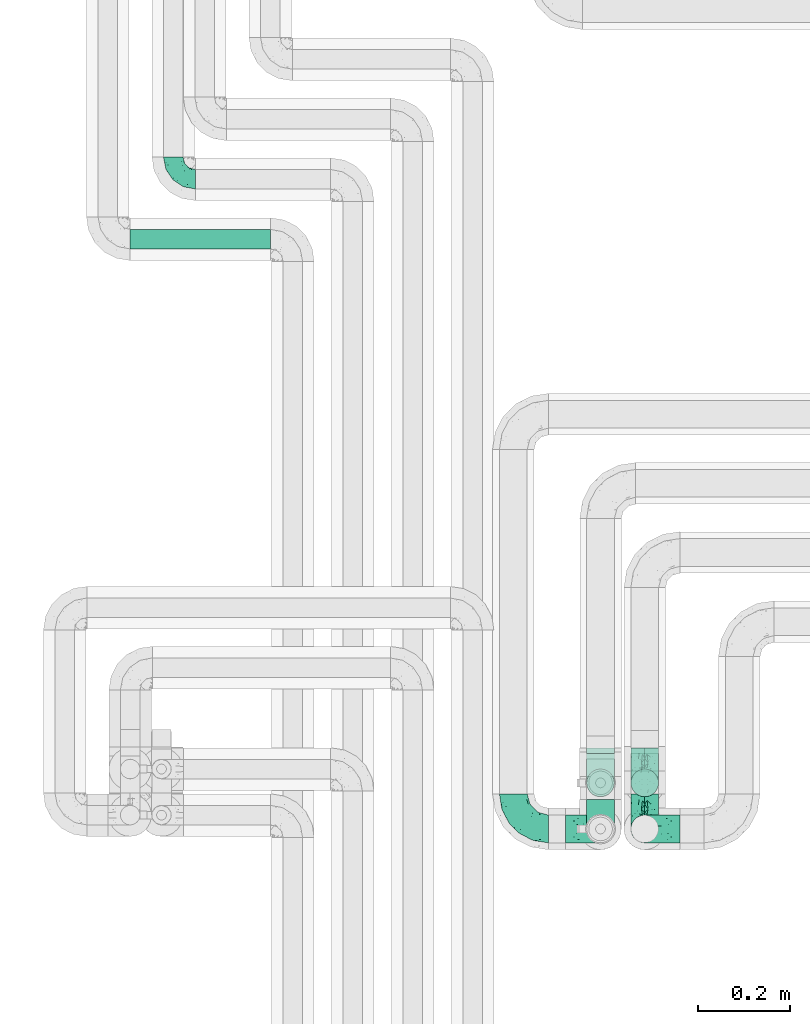
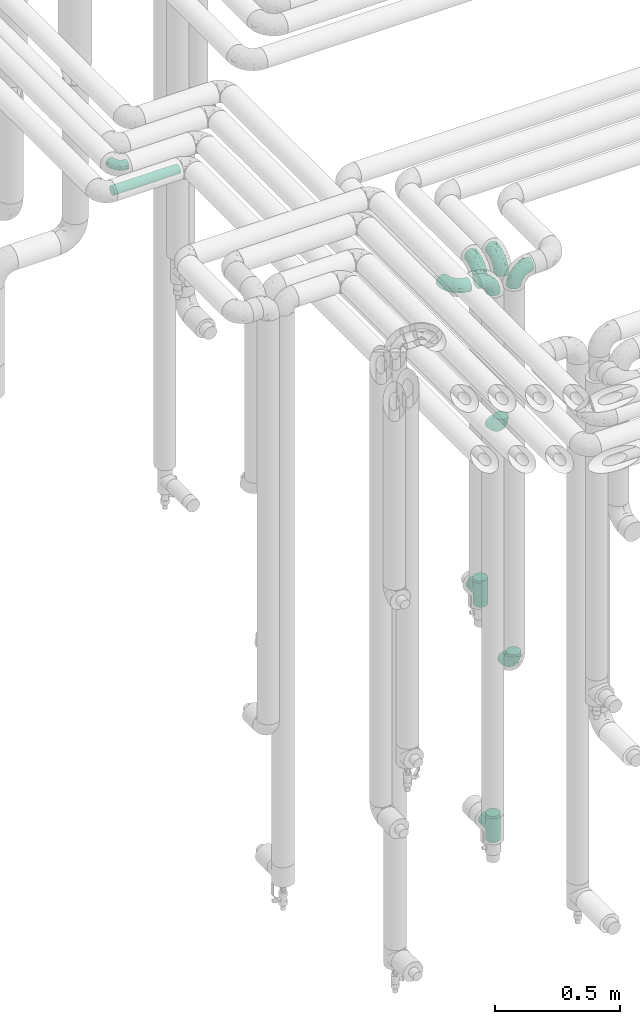
# One storey, part 632 of 824: 10 flow fittings, 1 flow segment.
"""IFC2X3 building model written with IfcOpenShell, lengths in millimetres."""

from ifc_helpers import new_model, entity, si_unit, converted_unit, derived_unit, direction, frame, origin, origin_2d_with_axis, place, context, subcontext, project, spatial, circle, extrude, faceted_brep, source, transform, mapped, material, type_object, type_shapes, element, save


model = new_model("IFC2X3")

# Units and contexts
model_context = context("Model", 3, precision=0.01, world=origin(), true_north=direction((6.12303176911189e-17, 1.0)))
body_context = subcontext(model_context, "Body", "Model", "MODEL_VIEW")
ifc_project = project(units=[si_unit("LENGTHUNIT", "METRE", prefix="MILLI"), si_unit("AREAUNIT", "SQUARE_METRE"), si_unit("VOLUMEUNIT", "CUBIC_METRE"), converted_unit("PLANEANGLEUNIT", "DEGREE", entity("IfcRatioMeasure", 0.0174532925199433), si_unit("PLANEANGLEUNIT", "RADIAN"), dimensions=[0, 0, 0, 0, 0, 0, 0]), si_unit("MASSUNIT", "GRAM", prefix="KILO"), derived_unit("MASSDENSITYUNIT", [(si_unit("MASSUNIT", "GRAM", prefix="KILO"), 1), (si_unit("LENGTHUNIT", "METRE"), -3)]), derived_unit("MOMENTOFINERTIAUNIT", [(si_unit("LENGTHUNIT", "METRE"), 4)]), si_unit("TIMEUNIT", "SECOND"), si_unit("FREQUENCYUNIT", "HERTZ"), si_unit("THERMODYNAMICTEMPERATUREUNIT", "DEGREE_CELSIUS"), derived_unit("THERMALTRANSMITTANCEUNIT", [(si_unit("MASSUNIT", "GRAM", prefix="KILO"), 1), (si_unit("THERMODYNAMICTEMPERATUREUNIT", "KELVIN"), -1), (si_unit("TIMEUNIT", "SECOND"), -3)]), derived_unit("VOLUMETRICFLOWRATEUNIT", [(si_unit("LENGTHUNIT", "METRE"), 3), (si_unit("TIMEUNIT", "SECOND"), -1)]), derived_unit("MASSFLOWRATEUNIT", [(si_unit("MASSUNIT", "GRAM", prefix="KILO"), 1), (si_unit("TIMEUNIT", "SECOND"), -1)]), derived_unit("ROTATIONALFREQUENCYUNIT", [(si_unit("TIMEUNIT", "SECOND"), -1)]), si_unit("ELECTRICCURRENTUNIT", "AMPERE"), si_unit("ELECTRICVOLTAGEUNIT", "VOLT"), si_unit("POWERUNIT", "WATT"), si_unit("FORCEUNIT", "NEWTON", prefix="KILO"), si_unit("ILLUMINANCEUNIT", "LUX"), si_unit("LUMINOUSFLUXUNIT", "LUMEN"), si_unit("LUMINOUSINTENSITYUNIT", "CANDELA"), derived_unit("USERDEFINED", [(si_unit("MASSUNIT", "GRAM", prefix="KILO"), -1), (si_unit("LENGTHUNIT", "METRE"), -2), (si_unit("TIMEUNIT", "SECOND"), 3), (si_unit("LUMINOUSFLUXUNIT", "LUMEN"), 1)]), derived_unit("LINEARVELOCITYUNIT", [(si_unit("LENGTHUNIT", "METRE"), 1), (si_unit("TIMEUNIT", "SECOND"), -1)]), si_unit("PRESSUREUNIT", "PASCAL"), derived_unit("USERDEFINED", [(si_unit("LENGTHUNIT", "METRE"), -2), (si_unit("MASSUNIT", "GRAM", prefix="KILO"), 1), (si_unit("TIMEUNIT", "SECOND"), -2)]), derived_unit("LINEARFORCEUNIT", [(si_unit("MASSUNIT", "GRAM", prefix="KILO"), 1), (si_unit("LENGTHUNIT", "METRE"), 1), (si_unit("TIMEUNIT", "SECOND"), -2), (si_unit("LENGTHUNIT", "METRE"), -1)]), derived_unit("PLANARFORCEUNIT", [(si_unit("MASSUNIT", "GRAM", prefix="KILO"), 1), (si_unit("LENGTHUNIT", "METRE"), 1), (si_unit("TIMEUNIT", "SECOND"), -2), (si_unit("LENGTHUNIT", "METRE"), -2)])], contexts=[model_context])

# Site, building, storey
site_placement = place(None, origin())
site = spatial("IfcSite", under=ifc_project, at=site_placement, CompositionType="ELEMENT")
building_placement = place(site_placement, origin())
building = spatial("IfcBuilding", under=site, at=building_placement, CompositionType="ELEMENT")
storey_placement = place(building_placement, frame((0.0, 0.0, 28200.0)))
storey = spatial("IfcBuildingStorey", under=building, at=storey_placement, CompositionType="ELEMENT", Elevation=28200.0)

# Flow segment
pipe_segment_type = type_object("IfcPipeSegmentType", PredefinedType="NOTDEFINED")
flow_segment_placement = place(storey_placement, frame((30563.05, 16968.46, 2977.25)))
element("IfcFlowSegment", 1, at=flow_segment_placement, inside=storey, type_object=pipe_segment_type, context=body_context, shape_type="SweptSolid", body=[
    extrude(circle(Radius=21.15, at=origin_2d_with_axis()), frame((0.0, 22.75, 22.75), z_axis=(1.0, 0.0, 0.0), x_axis=(0.0, -1.0, 0.0)), (0.0, 0.0, 1.0), 305.473199999971),
])

# Flow fittings
ifc_material = material()
pipe_fitting_type_1 = type_object("IfcPipeFittingType", PredefinedType="NOTDEFINED", material=ifc_material)
shared_shape_1 = source(origin(), body_context, "Body", "Brep", [
    faceted_brep([(-48.0, 10.6, -18.36), (-48.0, 5.49, -20.48), (-48.0, 0.0, -21.2), (-48.0, -5.49, -20.48), (-48.0, -10.6, -18.36), (-48.0, -14.99, -14.99), (-48.0, -18.36, -10.6), (-48.0, -20.48, -5.49), (-48.0, -21.2, 0.0), (-48.0, -20.48, 5.49), (-48.0, -18.36, 10.6), (-48.0, -14.99, 14.99), (-48.0, -10.6, 18.36), (-48.0, -5.49, 20.48), (-48.0, 0.0, 21.2), (-48.0, 5.49, 20.48), (-48.0, 10.6, 18.36), (-48.0, 14.99, 14.99), (-48.0, 18.36, 10.6), (-48.0, 20.48, 5.49), (-48.0, 21.2, 0.0), (-48.0, 20.48, -5.49), (-48.0, 18.36, -10.6), (-48.0, 14.99, -14.99), (0.0, 48.0, -21.2), (-5.49, 48.0, -20.48), (-10.6, 48.0, -18.36), (-14.99, 48.0, -14.99), (-18.36, 48.0, -10.6), (-20.48, 48.0, -5.49), (-21.2, 48.0, 0.0), (-20.48, 48.0, 5.49), (-18.36, 48.0, 10.6), (-14.99, 48.0, 14.99), (-10.6, 48.0, 18.36), (-5.49, 48.0, 20.48), (0.0, 48.0, 21.2), (5.49, 48.0, 20.48), (10.6, 48.0, 18.36), (14.99, 48.0, 14.99), (18.36, 48.0, 10.6), (20.48, 48.0, 5.49), (21.2, 48.0, 0.0), (20.48, 48.0, -5.49), (18.36, 48.0, -10.6), (14.99, 48.0, -14.99), (10.6, 48.0, -18.36), (5.49, 48.0, -20.48), (-35.25, -16.22, 12.01), (-34.76, -18.57, 0.0), (-20.87, -12.37, 10.9), (-31.49, -11.78, 15.9), (-37.0, -2.58, 20.86), (-33.89, 3.62, 21.15), (-31.81, -18.14, 6.76), (-5.78, 5.78, 17.67), (-19.42, -4.1, 17.86), (-9.6, -3.39, 13.73), (-35.44, -7.73, 19.13), (11.78, 31.49, 15.9), (-5.93, -5.46, 6.95), (-18.45, -13.78, 5.46), (-10.29, -8.43, 0.0), (-24.6, 0.55, 20.62), (-37.28, 17.94, 13.81), (-33.38, 22.85, 9.59), (-41.46, 20.06, 8.75), (-29.51, 20.45, 15.16), (-15.04, 10.79, 21.13), (-7.08, 16.98, 20.93), (-8.39, 23.51, 21.15), (-40.86, 13.03, 17.26), (-8.05, 41.26, 19.83), (-3.21, 35.97, 21.14), (8.53, 19.66, 14.74), (4.1, 19.42, 17.86), (-37.72, 22.66, 4.78), (-37.07, 8.58, 19.98), (-13.0, 5.43, 19.97), (-3.78, 13.93, 19.7), (3.02, 8.69, 13.43), (-2.27, -0.05, 10.65), (6.22, 6.99, 7.09), (-22.25, 34.6, 9.45), (18.14, 31.81, 6.76), (16.22, 35.25, 12.01), (12.37, 20.87, 10.9), (7.73, 35.44, 19.13), (-21.52, -15.93, 0.0), (2.58, 37.0, 20.86), (18.57, 34.76, 0.0), (13.78, 18.45, 5.46), (15.93, 21.52, 0.0), (-20.03, -8.54, 14.9), (-28.6, 28.6, 5.16), (-24.79, 34.6, 0.0), (-34.6, 24.79, 0.0), (-22.81, 37.41, 4.68), (-23.36, 26.33, 14.79), (-13.68, 37.05, 17.49), (-17.72, 38.12, 13.73), (-26.25, 27.3, 11.24), (-9.71, 32.34, 20.14), (-17.26, 25.6, 18.71), (-26.33, 9.99, 20.77), (-24.06, 6.05, 21.2), (-25.02, 15.46, 19.56), (-24.3, 20.72, 17.57), (-31.95, 15.23, 17.8), (-13.53, 24.7, 20.21), (-17.6, 17.6, 20.6), (-0.55, 24.6, 20.62), (-11.41, -7.48, 10.43), (0.93, -0.93, 0.0), (8.43, 10.29, 0.0), (-11.41, -7.48, -10.43), (-20.1, -8.84, -14.66), (-9.6, -3.39, -13.73), (7.73, 35.44, -19.13), (4.1, 19.42, -17.86), (-0.55, 24.6, -20.62), (-38.12, 17.72, -13.73), (-37.05, 13.68, -17.49), (-32.34, 9.71, -20.14), (-41.26, 8.05, -19.83), (-37.41, 22.81, -4.68), (-23.51, 8.39, -21.15), (-35.97, 3.21, -21.14), (-28.6, 28.6, -5.16), (-31.81, -18.14, -6.76), (-18.45, -13.78, -5.46), (-25.6, 17.26, -18.71), (-19.42, -4.1, -17.86), (-17.94, 37.28, -13.81), (-22.85, 33.38, -9.59), (-20.06, 41.46, -8.75), (-31.49, -11.78, -15.9), (-35.25, -16.22, -12.01), (8.53, 19.66, -14.74), (11.78, 31.49, -15.9), (-9.99, 26.33, -20.77), (-6.05, 24.06, -21.2), (-10.79, 15.04, -21.13), (-37.0, -2.58, -20.86), (-16.98, 7.08, -20.93), (-5.43, 13.0, -19.97), (-13.93, 3.78, -19.7), (-20.87, -12.37, -10.9), (-26.33, 23.36, -14.79), (-22.66, 37.72, -4.78), (13.78, 18.45, -5.46), (18.14, 31.81, -6.76), (-15.46, 25.02, -19.56), (-20.72, 24.3, -17.57), (16.22, 35.25, -12.01), (-13.03, 40.86, -17.26), (-8.58, 37.07, -19.98), (2.58, 37.0, -20.86), (-3.62, 33.89, -21.15), (-34.6, 22.25, -9.45), (6.22, 6.99, -7.09), (-20.45, 29.51, -15.16), (-35.44, -7.73, -19.13), (12.37, 20.87, -10.9), (-27.3, 26.25, -11.24), (-15.23, 31.95, -17.8), (-24.7, 13.53, -20.21), (-24.6, 0.55, -20.62), (-5.78, 5.78, -17.67), (-17.6, 17.6, -20.6), (3.02, 8.69, -13.43), (-5.93, -5.46, -6.95), (-2.27, -0.05, -10.65)], [[[0, 1, 2, 3, 4, 5, 6, 7, 8, 9, 10, 11, 12, 13, 14, 15, 16, 17, 18, 19, 20, 21, 22, 23]], [[24, 25, 26, 27, 28, 29, 30, 31, 32, 33, 34, 35, 36, 37, 38, 39, 40, 41, 42, 43, 44, 45, 46, 47]], [[10, 48, 11]], [[9, 8, 49]], [[48, 50, 51]], [[14, 52, 53]], [[10, 54, 48]], [[9, 54, 10]], [[55, 56, 57]], [[51, 12, 11]], [[51, 58, 12]], [[59, 39, 38]], [[60, 61, 62]], [[58, 56, 63]], [[64, 65, 66]], [[67, 65, 64]], [[68, 69, 70]], [[16, 71, 17]], [[13, 52, 14]], [[35, 72, 73]], [[14, 53, 15]], [[17, 64, 18]], [[74, 59, 75]], [[20, 19, 76]], [[66, 19, 18]], [[77, 15, 53]], [[15, 77, 16]], [[69, 78, 79]], [[80, 81, 82]], [[32, 31, 83]], [[84, 85, 86]], [[59, 87, 75]], [[61, 54, 88]], [[36, 89, 37]], [[84, 41, 40]], [[36, 35, 73]], [[90, 41, 84]], [[40, 39, 85]], [[12, 58, 13]], [[85, 84, 40]], [[91, 84, 86]], [[84, 92, 90]], [[87, 38, 37]], [[93, 56, 51]], [[65, 94, 76]], [[94, 95, 96]], [[84, 91, 92]], [[95, 97, 30]], [[98, 99, 100]], [[76, 94, 96]], [[101, 98, 83]], [[100, 99, 33]], [[102, 70, 73]], [[103, 102, 99]], [[94, 97, 95]], [[72, 99, 102]], [[72, 35, 34]], [[34, 33, 99]], [[9, 49, 54]], [[87, 59, 38]], [[104, 105, 68]], [[106, 103, 107]], [[106, 77, 104]], [[71, 64, 17]], [[108, 107, 67]], [[33, 32, 100]], [[109, 103, 110]], [[102, 109, 70]], [[89, 73, 111]], [[50, 48, 54]], [[51, 11, 48]], [[56, 58, 51]], [[88, 54, 49]], [[52, 58, 63]], [[50, 112, 93]], [[56, 55, 78]], [[39, 59, 85]], [[86, 85, 59]], [[89, 87, 37]], [[42, 41, 90]], [[111, 79, 75]], [[111, 75, 87]], [[75, 55, 80]], [[104, 77, 53]], [[71, 77, 108]], [[32, 83, 100]], [[98, 100, 83]], [[99, 98, 103]], [[106, 107, 108]], [[68, 70, 110]], [[111, 73, 70]], [[68, 110, 104]], [[68, 63, 78]], [[57, 93, 112]], [[80, 55, 57]], [[61, 50, 54]], [[80, 82, 86]], [[81, 57, 112]], [[74, 86, 59]], [[60, 113, 82]], [[82, 114, 91]], [[101, 94, 65]], [[97, 94, 83]], [[73, 89, 36]], [[87, 89, 111]], [[58, 52, 13]], [[53, 52, 63]], [[104, 53, 105]], [[106, 104, 110]], [[20, 76, 96]], [[76, 19, 66]], [[103, 106, 110]], [[77, 106, 108]], [[103, 98, 107]], [[67, 107, 98]], [[67, 98, 101]], [[108, 67, 64]], [[53, 63, 105]], [[63, 68, 105]], [[83, 31, 97]], [[30, 97, 31]], [[62, 113, 60]], [[112, 61, 60]], [[61, 88, 62]], [[86, 82, 91]], [[56, 78, 63]], [[114, 82, 113]], [[114, 92, 91]], [[79, 78, 55]], [[75, 79, 55]], [[69, 79, 111]], [[70, 69, 111]], [[78, 69, 68]], [[77, 71, 16]], [[64, 71, 108]], [[64, 66, 18]], [[76, 66, 65]], [[99, 72, 34]], [[73, 72, 102]], [[94, 101, 83]], [[67, 101, 65]], [[75, 80, 74]], [[80, 86, 74]], [[70, 109, 110]], [[102, 103, 109]], [[50, 93, 51]], [[57, 56, 93]], [[61, 112, 50]], [[81, 112, 60]], [[82, 81, 60]], [[80, 57, 81]], [[115, 116, 117]], [[118, 119, 120]], [[121, 122, 23]], [[123, 124, 122]], [[96, 125, 20]], [[123, 126, 127]], [[128, 96, 95]], [[129, 130, 88]], [[123, 122, 131]], [[116, 132, 117]], [[133, 134, 135]], [[0, 124, 1]], [[5, 136, 137]], [[138, 119, 139]], [[129, 88, 49]], [[140, 141, 142]], [[6, 5, 137]], [[46, 118, 47]], [[143, 3, 2]], [[144, 145, 146]], [[6, 129, 7]], [[129, 137, 147]], [[127, 2, 1]], [[148, 122, 121]], [[128, 125, 96]], [[134, 128, 149]], [[95, 149, 128]], [[150, 151, 92]], [[30, 29, 149]], [[152, 131, 153]], [[27, 133, 28]], [[154, 45, 44]], [[136, 5, 4]], [[27, 26, 155]], [[156, 26, 25]], [[24, 157, 158]], [[24, 47, 157]], [[22, 21, 159]], [[160, 150, 114]], [[134, 133, 161]], [[142, 144, 126]], [[46, 139, 118]], [[162, 136, 4]], [[156, 25, 158]], [[1, 124, 127]], [[115, 147, 116]], [[45, 154, 139]], [[139, 46, 45]], [[154, 163, 139]], [[162, 4, 3]], [[42, 90, 43]], [[130, 129, 147]], [[49, 7, 129]], [[43, 151, 44]], [[0, 23, 122]], [[24, 158, 25]], [[136, 162, 132]], [[135, 29, 28]], [[43, 90, 151]], [[164, 148, 159]], [[152, 156, 140]], [[155, 133, 27]], [[165, 153, 161]], [[23, 22, 121]], [[123, 131, 166]], [[123, 166, 126]], [[143, 127, 167]], [[147, 137, 136]], [[8, 7, 49]], [[129, 6, 137]], [[143, 162, 3]], [[167, 146, 132]], [[167, 132, 162]], [[132, 168, 117]], [[44, 151, 154]], [[92, 151, 90]], [[163, 154, 151]], [[119, 118, 139]], [[157, 118, 120]], [[138, 139, 163]], [[119, 168, 145]], [[140, 156, 158]], [[155, 156, 165]], [[22, 159, 121]], [[148, 121, 159]], [[122, 148, 131]], [[152, 153, 165]], [[142, 126, 169]], [[167, 127, 126]], [[142, 169, 140]], [[142, 120, 145]], [[168, 170, 117]], [[160, 171, 172]], [[115, 172, 171]], [[171, 62, 130]], [[119, 170, 168]], [[170, 163, 160]], [[150, 163, 151]], [[113, 171, 160]], [[164, 128, 134]], [[125, 128, 159]], [[127, 143, 2]], [[162, 143, 167]], [[118, 157, 47]], [[158, 157, 120]], [[140, 158, 141]], [[152, 140, 169]], [[30, 149, 95]], [[149, 29, 135]], [[131, 152, 169]], [[156, 152, 165]], [[131, 148, 153]], [[161, 153, 148]], [[161, 148, 164]], [[165, 161, 133]], [[158, 120, 141]], [[120, 142, 141]], [[159, 21, 125]], [[20, 125, 21]], [[115, 130, 147]], [[114, 113, 160]], [[62, 171, 113]], [[62, 88, 130]], [[160, 163, 150]], [[150, 92, 114]], [[119, 145, 120]], [[146, 145, 168]], [[132, 146, 168]], [[144, 146, 167]], [[126, 144, 167]], [[145, 144, 142]], [[156, 155, 26]], [[133, 155, 165]], [[133, 135, 28]], [[149, 135, 134]], [[122, 124, 0]], [[127, 124, 123]], [[128, 164, 159]], [[161, 164, 134]], [[163, 170, 138]], [[170, 119, 138]], [[131, 169, 166]], [[126, 166, 169]], [[147, 136, 116]], [[132, 116, 136]], [[172, 115, 117]], [[130, 115, 171]], [[117, 170, 172]], [[160, 172, 170]]]),
])
type_shapes(pipe_fitting_type_1, [shared_shape_1])
flow_fitting_placement = place(storey_placement, frame((30657.05, 17121.2, 3000.0), z_axis=(0.0, 0.0, 1.0), x_axis=(0.0, -1.0, 0.0)))
element("IfcFlowFitting", 2, at=flow_fitting_placement, inside=storey, type_object=pipe_fitting_type_1, material=ifc_material, context=body_context, shape_type="MappedRepresentation", body=[
    mapped(shared_shape_1, transform((0.0, 0.0, 0.0), scale=1.0)),
])
pipe_fitting_type_2 = type_object("IfcPipeFittingType", PredefinedType="NOTDEFINED", material=ifc_material)
shared_shape_2 = source(origin(), body_context, "Body", "Brep", [
    faceted_brep([(-76.0, 15.07, -26.11), (-76.0, 7.8, -29.12), (-76.0, 0.0, -30.15), (-76.0, -7.8, -29.12), (-76.0, -15.08, -26.11), (-76.0, -21.32, -21.32), (-76.0, -26.11, -15.08), (-76.0, -29.12, -7.8), (-76.0, -30.15, 0.0), (-76.0, -29.12, 7.8), (-76.0, -26.11, 15.07), (-76.0, -21.32, 21.32), (-76.0, -15.08, 26.11), (-76.0, -7.8, 29.12), (-76.0, 0.0, 30.15), (-76.0, 7.8, 29.12), (-76.0, 15.07, 26.11), (-76.0, 21.32, 21.32), (-76.0, 26.11, 15.07), (-76.0, 29.12, 7.8), (-76.0, 30.15, 0.0), (-76.0, 29.12, -7.8), (-76.0, 26.11, -15.08), (-76.0, 21.32, -21.32), (0.0, 76.0, -30.15), (-7.8, 76.0, -29.12), (-15.07, 76.0, -26.11), (-21.32, 76.0, -21.32), (-26.11, 76.0, -15.08), (-29.12, 76.0, -7.8), (-30.15, 76.0, 0.0), (-29.12, 76.0, 7.8), (-26.11, 76.0, 15.07), (-21.32, 76.0, 21.32), (-15.07, 76.0, 26.11), (-7.8, 76.0, 29.12), (0.0, 76.0, 30.15), (7.8, 76.0, 29.12), (15.08, 76.0, 26.11), (21.32, 76.0, 21.32), (26.11, 76.0, 15.07), (29.12, 76.0, 7.8), (30.15, 76.0, 0.0), (29.12, 76.0, -7.8), (26.11, 76.0, -15.08), (21.32, 76.0, -21.32), (15.08, 76.0, -26.11), (7.8, 76.0, -29.12), (10.79, 31.43, 21.07), (4.32, 31.7, 25.72), (1.65, 15.19, 19.92), (-61.17, -27.8, 0.0), (-51.1, -25.49, 9.84), (-56.14, -10.61, 27.27), (-31.7, -4.32, 25.72), (-39.75, 1.72, 29.41), (-43.2, -24.95, 0.0), (-1.86, 1.86, 0.0), (4.49, 7.65, 5.78), (-7.82, -4.61, 5.83), (-56.21, -22.79, 17.21), (-58.98, -3.38, 29.7), (-53.96, 5.6, 30.07), (-10.86, 10.86, 25.48), (-17.2, -2.6, 20.44), (-49.15, -16.01, 22.7), (-22.18, -14.24, 7.99), (-28.4, -17.42, 0.0), (-13.61, -9.88, 0.0), (-39.0, 23.48, 27.76), (-58.76, 12.54, 28.36), (-41.61, 15.41, 29.48), (16.01, 49.15, 22.7), (-58.55, 25.93, 19.53), (-51.53, 33.5, 13.51), (-64.92, 28.76, 12.4), (-7.48, 23.14, 28.25), (-1.72, 39.75, 29.41), (-12.04, 27.88, 29.88), (-63.91, 18.81, 24.52), (-11.63, 65.16, 28.18), (-4.97, 57.02, 30.05), (9.88, 13.61, 0.0), (-62.5, 31.74, 5.02), (-45.17, 30.98, 21.2), (-21.78, 9.76, 28.58), (10.61, 56.14, 27.27), (-32.09, 54.42, 13.26), (22.79, 56.21, 17.21), (15.38, 31.17, 15.63), (25.49, 51.1, 9.84), (21.84, 36.35, 5.92), (24.95, 43.2, 0.0), (3.38, 58.98, 29.7), (-31.17, -15.38, 15.63), (-39.39, 41.78, 15.45), (-34.56, 41.13, 20.79), (-39.81, -23.25, 5.49), (27.8, 61.17, 0.0), (-31.74, 62.5, 5.02), (-53.07, 36.29, 0.0), (-42.95, 42.95, 7.29), (-36.29, 53.07, 0.0), (-19.83, 58.51, 24.79), (-25.48, 60.2, 19.41), (-14.53, 50.96, 28.57), (-13.31, 37.09, 30.07), (-26.16, 40.06, 26.4), (-32.43, -10.35, 21.9), (17.42, 28.4, 0.0), (14.24, 22.18, 7.99), (-38.67, 9.72, 30.15), (-24.66, 17.36, 30.09), (-37.08, 31.49, 24.99), (-49.27, 22.83, 25.24), (-20.8, 38.81, 28.63), (-27.58, 27.58, 29.2), (-36.07, -20.23, 10.71), (-15.19, -6.16, 14.9), (6.6, 15.4, 14.49), (-2.51, 2.51, 11.35), (-65.16, 11.63, -28.18), (-49.15, -16.01, -22.7), (-57.02, 4.97, -30.05), (-25.93, 58.55, -19.53), (-33.5, 51.53, -13.51), (-28.76, 64.92, -12.4), (-60.2, 25.48, -19.41), (-58.51, 19.83, -24.79), (4.61, 7.82, -5.83), (-7.65, -4.49, -5.78), (-2.51, 2.51, -11.35), (-62.5, 31.74, -5.02), (-50.96, 14.53, -28.57), (-37.09, 13.31, -30.07), (-42.95, 42.95, -7.29), (25.49, 51.1, -9.84), (22.79, 56.21, -17.21), (-40.06, 26.16, -26.4), (3.38, 58.98, -29.7), (-5.6, 53.96, -30.07), (-27.88, 12.04, -29.88), (-9.76, 21.78, -28.58), (-23.14, 7.48, -28.25), (-51.1, -25.49, -9.84), (15.38, 31.17, -15.63), (16.01, 49.15, -22.7), (-23.48, 39.0, -27.76), (-12.54, 58.76, -28.36), (-15.41, 41.61, -29.48), (-56.21, -22.79, -17.21), (-9.72, 38.67, -30.15), (-17.36, 24.66, -30.09), (-22.18, -14.24, -7.99), (-41.13, 34.56, -20.79), (-31.74, 62.5, -5.02), (-58.98, -3.38, -29.7), (-31.17, -15.38, -15.63), (-56.14, -10.61, -27.27), (14.24, 22.18, -7.99), (23.25, 39.81, -5.49), (-31.49, 37.08, -24.99), (-15.19, -6.16, -14.9), (1.65, 15.19, -19.92), (-18.81, 63.91, -24.52), (-32.59, -11.62, -20.84), (-31.7, -4.32, -25.72), (-17.2, -2.6, -20.44), (-39.75, 1.72, -29.41), (-54.42, 32.09, -13.26), (-30.98, 45.17, -21.2), (10.61, 56.14, -27.27), (10.23, 31.31, -21.52), (4.32, 31.7, -25.72), (-41.78, 39.39, -15.45), (-1.72, 39.75, -29.41), (-36.35, -21.84, -5.92), (-22.83, 49.27, -25.24), (-38.81, 20.8, -28.63), (-27.58, 27.58, -29.2), (-10.86, 10.86, -25.48), (20.23, 36.07, -10.71), (6.6, 15.4, -14.49)], [[[0, 1, 2, 3, 4, 5, 6, 7, 8, 9, 10, 11, 12, 13, 14, 15, 16, 17, 18, 19, 20, 21, 22, 23]], [[24, 25, 26, 27, 28, 29, 30, 31, 32, 33, 34, 35, 36, 37, 38, 39, 40, 41, 42, 43, 44, 45, 46, 47]], [[48, 49, 50]], [[51, 52, 9]], [[53, 54, 55]], [[9, 52, 10]], [[56, 52, 51]], [[57, 58, 59]], [[11, 10, 60]], [[14, 61, 62]], [[63, 54, 64]], [[65, 12, 11]], [[65, 53, 12]], [[66, 67, 68]], [[69, 70, 71]], [[72, 39, 38]], [[73, 74, 75]], [[15, 70, 16]], [[76, 77, 78]], [[16, 79, 17]], [[13, 61, 14]], [[35, 80, 81]], [[14, 62, 15]], [[17, 73, 18]], [[57, 82, 58]], [[20, 19, 83]], [[75, 19, 18]], [[70, 15, 62]], [[73, 84, 74]], [[78, 85, 76]], [[38, 86, 72]], [[32, 31, 87]], [[88, 89, 90]], [[91, 92, 90]], [[72, 86, 49]], [[36, 93, 37]], [[75, 83, 19]], [[36, 35, 81]], [[60, 94, 65]], [[40, 90, 41]], [[95, 96, 87]], [[88, 90, 40]], [[66, 97, 67]], [[90, 98, 41]], [[40, 39, 88]], [[99, 31, 30]], [[20, 83, 100]], [[101, 102, 100]], [[52, 60, 10]], [[102, 99, 30]], [[96, 103, 104]], [[83, 101, 100]], [[12, 53, 13]], [[104, 103, 33]], [[105, 106, 81]], [[107, 105, 103]], [[64, 54, 108]], [[80, 103, 105]], [[80, 35, 34]], [[34, 33, 103]], [[86, 38, 37]], [[109, 110, 82]], [[71, 111, 112]], [[69, 107, 113]], [[79, 73, 17]], [[114, 113, 84]], [[33, 32, 104]], [[115, 107, 116]], [[105, 115, 106]], [[93, 81, 77]], [[54, 53, 65]], [[61, 53, 55]], [[108, 94, 64]], [[54, 63, 85]], [[93, 86, 37]], [[77, 76, 49]], [[77, 49, 86]], [[49, 63, 50]], [[60, 52, 117]], [[65, 11, 60]], [[39, 72, 88]], [[89, 88, 72]], [[71, 70, 62]], [[79, 70, 114]], [[103, 96, 107]], [[69, 113, 114]], [[112, 106, 116]], [[77, 81, 106]], [[112, 116, 71]], [[112, 55, 85]], [[64, 50, 63]], [[57, 59, 68]], [[32, 87, 104]], [[96, 104, 87]], [[94, 118, 64]], [[50, 119, 89]], [[50, 64, 118]], [[50, 89, 48]], [[81, 93, 36]], [[86, 93, 77]], [[53, 61, 13]], [[62, 61, 55]], [[71, 62, 111]], [[69, 71, 116]], [[95, 101, 74]], [[99, 101, 87]], [[118, 66, 59]], [[117, 97, 66]], [[117, 66, 94]], [[91, 89, 110]], [[91, 110, 109]], [[110, 89, 119]], [[9, 8, 51]], [[98, 90, 92]], [[98, 42, 41]], [[101, 83, 74]], [[101, 99, 102]], [[87, 31, 99]], [[62, 55, 111]], [[55, 112, 111]], [[107, 69, 116]], [[70, 69, 114]], [[107, 96, 113]], [[84, 113, 96]], [[84, 96, 95]], [[114, 84, 73]], [[70, 79, 16]], [[73, 79, 114]], [[54, 85, 55]], [[76, 85, 63]], [[49, 76, 63]], [[77, 106, 78]], [[106, 112, 78]], [[85, 78, 112]], [[73, 75, 18]], [[83, 75, 74]], [[103, 80, 34]], [[81, 80, 105]], [[101, 95, 87]], [[84, 95, 74]], [[106, 115, 116]], [[105, 107, 115]], [[120, 59, 58]], [[82, 110, 58]], [[119, 58, 110]], [[118, 59, 120]], [[66, 68, 59]], [[54, 65, 108]], [[94, 108, 65]], [[66, 118, 94]], [[50, 118, 120]], [[50, 120, 119]], [[119, 120, 58]], [[89, 72, 48]], [[49, 48, 72]], [[60, 117, 94]], [[117, 52, 97]], [[52, 56, 97]], [[67, 97, 56]], [[92, 91, 109]], [[89, 91, 90]], [[121, 1, 0]], [[122, 5, 4]], [[2, 1, 123]], [[124, 125, 126]], [[127, 128, 23]], [[129, 130, 131]], [[100, 132, 20]], [[133, 134, 123]], [[135, 100, 102]], [[136, 137, 44]], [[133, 128, 138]], [[24, 139, 140]], [[141, 142, 143]], [[121, 128, 133]], [[6, 144, 7]], [[137, 145, 146]], [[144, 51, 7]], [[147, 148, 149]], [[144, 6, 150]], [[149, 151, 152]], [[153, 68, 67]], [[154, 128, 127]], [[30, 155, 102]], [[43, 42, 98]], [[156, 3, 2]], [[157, 144, 150]], [[158, 4, 3]], [[24, 140, 25]], [[155, 135, 102]], [[159, 160, 109]], [[30, 29, 155]], [[147, 138, 161]], [[27, 124, 28]], [[57, 129, 82]], [[162, 163, 131]], [[27, 26, 164]], [[148, 26, 25]], [[165, 166, 167]], [[24, 47, 139]], [[143, 168, 141]], [[22, 21, 169]], [[125, 124, 170]], [[148, 25, 140]], [[46, 146, 171]], [[158, 122, 4]], [[0, 23, 128]], [[1, 121, 123]], [[109, 82, 159]], [[45, 44, 137]], [[146, 46, 45]], [[136, 43, 98]], [[132, 21, 20]], [[136, 98, 92]], [[172, 173, 146]], [[46, 171, 47]], [[43, 136, 44]], [[174, 154, 169]], [[171, 173, 175]], [[6, 5, 150]], [[126, 29, 28]], [[176, 56, 144]], [[122, 158, 166]], [[164, 124, 27]], [[177, 161, 170]], [[23, 22, 127]], [[178, 138, 179]], [[133, 178, 134]], [[156, 123, 168]], [[156, 158, 3]], [[168, 143, 166]], [[168, 166, 158]], [[166, 180, 167]], [[173, 171, 146]], [[139, 171, 175]], [[172, 145, 163]], [[173, 180, 142]], [[5, 122, 150]], [[157, 150, 122]], [[137, 136, 181]], [[146, 45, 137]], [[149, 148, 140]], [[164, 148, 177]], [[128, 154, 138]], [[147, 161, 177]], [[152, 134, 179]], [[168, 123, 134]], [[152, 179, 149]], [[152, 175, 142]], [[57, 130, 129]], [[157, 165, 167]], [[22, 169, 127]], [[154, 127, 169]], [[163, 167, 180]], [[162, 157, 167]], [[173, 163, 180]], [[182, 163, 145]], [[123, 156, 2]], [[158, 156, 168]], [[171, 139, 47]], [[140, 139, 175]], [[149, 140, 151]], [[147, 149, 179]], [[174, 135, 125]], [[132, 135, 169]], [[176, 157, 153]], [[176, 153, 67]], [[153, 157, 162]], [[182, 159, 129]], [[181, 160, 159]], [[181, 159, 145]], [[51, 144, 56]], [[51, 8, 7]], [[135, 132, 100]], [[169, 21, 132]], [[126, 155, 29]], [[135, 155, 125]], [[140, 175, 151]], [[175, 152, 151]], [[138, 147, 179]], [[148, 147, 177]], [[138, 154, 161]], [[170, 161, 154]], [[170, 154, 174]], [[177, 170, 124]], [[148, 164, 26]], [[124, 164, 177]], [[173, 142, 175]], [[143, 142, 180]], [[166, 143, 180]], [[168, 134, 141]], [[134, 152, 141]], [[142, 141, 152]], [[124, 126, 28]], [[155, 126, 125]], [[128, 121, 0]], [[123, 121, 133]], [[135, 174, 169]], [[170, 174, 125]], [[134, 178, 179]], [[133, 138, 178]], [[130, 153, 162]], [[68, 153, 130]], [[57, 68, 130]], [[182, 129, 131]], [[159, 82, 129]], [[157, 122, 165]], [[166, 165, 122]], [[163, 162, 167]], [[162, 131, 130]], [[145, 172, 146]], [[163, 173, 172]], [[159, 182, 145]], [[131, 163, 182]], [[56, 176, 67]], [[157, 176, 144]], [[137, 181, 145]], [[181, 136, 160]], [[136, 92, 160]], [[109, 160, 92]]]),
])
type_shapes(pipe_fitting_type_2, [shared_shape_2])
for number, where, z_axis, x_axis in (
    (3, (31395.03, 15711.2, 3000.0), (0.0, 0.0, 1.0), (0.0, -1.0, 0.0)),
    (4, (31680.25, 15711.2, 3000.0), (0.0, -1.0, 0.0), (-1.0, 0.0, 0.0)),
    (5, (31584.25, 15711.2, 3000.0), (0.0, 1.0, 0.0), (1.0, 0.0, 0.0)),
    (6, (31584.25, 15811.2, 3000.0), (1.0, 0.0, 0.0), (0.0, -1.0, 0.0)),
    (7, (31680.25, 15811.2, 3000.0), (1.0, 0.0, 0.0), (0.0, -1.0, 0.0)),
    (8, (31680.25, 15811.2, 2150.0), (1.0, 0.0, 0.0), (0.0, 0.0, -1.0)),
    (9, (31680.25, 15711.2, 1060.0), (1.0, 0.0, 0.0), (0.0, 0.0, -1.0)),
):
    element("IfcFlowFitting", number, at=place(storey_placement, frame(where, z_axis=z_axis, x_axis=x_axis)), inside=storey, type_object=pipe_fitting_type_2, material=ifc_material, context=body_context, shape_type="MappedRepresentation", body=[
        mapped(shared_shape_2, transform((0.0, 0.0, 0.0), scale=1.0)),
    ])
pipe_fitting_type_3 = type_object("IfcPipeFittingType", PredefinedType="NOTDEFINED", material=ifc_material)
shared_shape_3 = source(origin(), body_context, "Body", "Brep", [
    faceted_brep([(-64.0, 15.07, -26.11), (-64.0, 7.8, -29.12), (-64.0, 0.0, -30.15), (-64.0, -7.8, -29.12), (-64.0, -15.08, -26.11), (-64.0, -21.32, -21.32), (-64.0, -26.11, -15.08), (-64.0, -29.12, -7.8), (-64.0, -30.15, 0.0), (-64.0, -29.12, 7.8), (-64.0, -26.11, 15.07), (-64.0, -21.32, 21.32), (-64.0, -15.08, 26.11), (-64.0, -7.8, 29.12), (-64.0, 0.0, 30.15), (-64.0, 7.8, 29.12), (-64.0, 15.07, 26.11), (-64.0, 21.32, 21.32), (-64.0, 26.11, 15.07), (-64.0, 29.12, 7.8), (-64.0, 30.15, 0.0), (-64.0, 29.12, -7.8), (-64.0, 26.11, -15.08), (-64.0, 21.32, -21.32), (64.0, 0.0, -30.15), (64.0, 7.8, -29.12), (64.0, 15.07, -26.11), (64.0, 21.32, -21.32), (64.0, 26.11, -15.08), (64.0, 29.12, -7.8), (64.0, 30.15, 0.0), (64.0, 29.12, 7.8), (64.0, 26.11, 15.07), (64.0, 21.32, 21.32), (64.0, 15.07, 26.11), (64.0, 7.8, 29.12), (64.0, 0.0, 30.15), (64.0, -7.8, 29.12), (64.0, -15.08, 26.11), (64.0, -21.32, 21.32), (64.0, -26.11, 15.07), (64.0, -29.12, 7.8), (64.0, -30.15, 0.0), (64.0, -29.12, -7.8), (64.0, -26.11, -15.08), (64.0, -21.32, -21.32), (64.0, -15.08, -26.11), (64.0, -7.8, -29.12), (29.06, -29.06, 8.05), (30.15, -30.15, 0.0), (-30.15, -30.15, 0.0), (26.09, -26.09, 15.1), (16.9, -16.9, 24.97), (21.88, -21.88, 20.75), (-29.06, -29.06, 8.05), (-26.09, -26.09, 15.1), (-21.88, -21.88, 20.75), (-16.9, -16.9, 24.97), (-11.47, -11.47, 27.88), (11.47, -11.47, 27.88), (5.79, -5.79, 29.59), (0.0, 0.0, 30.15), (-5.79, -5.79, 29.59), (5.79, -5.79, -29.59), (0.0, 0.0, -30.15), (-5.79, -5.79, -29.59), (-11.47, -11.47, -27.88), (11.47, -11.47, -27.88), (16.9, -16.9, -24.97), (21.88, -21.88, -20.75), (26.09, -26.09, -15.1), (29.06, -29.06, -8.05), (-16.9, -16.9, -24.97), (-21.88, -21.88, -20.75), (-29.06, -29.06, -8.05), (-26.09, -26.09, -15.1), (0.0, -64.0, -30.15), (7.8, -64.0, -29.12), (15.08, -64.0, -26.11), (21.32, -64.0, -21.32), (26.11, -64.0, -15.08), (29.12, -64.0, -7.8), (30.15, -64.0, 0.0), (29.12, -64.0, 7.8), (26.11, -64.0, 15.07), (21.32, -64.0, 21.32), (15.08, -64.0, 26.11), (7.8, -64.0, 29.12), (0.0, -64.0, 30.15), (-7.8, -64.0, 29.12), (-15.07, -64.0, 26.11), (-21.32, -64.0, 21.32), (-26.11, -64.0, 15.07), (-29.12, -64.0, 7.8), (-30.15, -64.0, 0.0), (-29.12, -64.0, -7.8), (-26.11, -64.0, -15.08), (-21.32, -64.0, -21.32), (-15.07, -64.0, -26.11), (-7.8, -64.0, -29.12)], [[[0, 1, 2, 3, 4, 5, 6, 7, 8, 9, 10, 11, 12, 13, 14, 15, 16, 17, 18, 19, 20, 21, 22, 23]], [[24, 25, 26, 27, 28, 29, 30, 31, 32, 33, 34, 35, 36, 37, 38, 39, 40, 41, 42, 43, 44, 45, 46, 47]], [[41, 40, 48]], [[42, 41, 49]], [[50, 9, 8]], [[49, 41, 48]], [[40, 51, 48]], [[39, 38, 52]], [[51, 40, 53]], [[52, 53, 39]], [[53, 40, 39]], [[50, 54, 9]], [[9, 54, 10]], [[54, 55, 10]], [[56, 57, 11]], [[11, 10, 56]], [[11, 57, 12]], [[56, 10, 55]], [[12, 57, 58]], [[52, 38, 59]], [[60, 36, 61]], [[62, 61, 14]], [[59, 37, 60]], [[37, 59, 38]], [[60, 37, 36]], [[61, 36, 35, 15, 14]], [[32, 31, 19, 18]], [[17, 16, 34, 33]], [[18, 17, 33, 32]], [[35, 34, 16, 15]], [[20, 19, 31, 30]], [[62, 13, 58]], [[13, 62, 14]], [[58, 13, 12]], [[27, 23, 22, 28]], [[22, 21, 29, 28]], [[0, 23, 27, 26]], [[20, 30, 29, 21]], [[24, 47, 63]], [[24, 64, 2, 1, 25]], [[64, 24, 63]], [[2, 64, 65]], [[26, 25, 1, 0]], [[65, 66, 3]], [[2, 65, 3]], [[66, 4, 3]], [[63, 47, 67]], [[46, 45, 68]], [[69, 68, 45]], [[44, 70, 69]], [[69, 45, 44]], [[46, 68, 67]], [[43, 42, 49]], [[7, 50, 8]], [[43, 71, 44]], [[71, 43, 49]], [[44, 71, 70]], [[72, 4, 66]], [[72, 5, 4]], [[5, 72, 73]], [[5, 73, 6]], [[74, 50, 7]], [[75, 74, 6]], [[74, 7, 6]], [[75, 6, 73]], [[46, 67, 47]], [[76, 77, 78, 79, 80, 81, 82, 83, 84, 85, 86, 87, 88, 89, 90, 91, 92, 93, 94, 95, 96, 97, 98, 99]], [[50, 94, 93]], [[54, 50, 93]], [[91, 90, 57]], [[56, 92, 91]], [[54, 93, 92]], [[58, 90, 89]], [[55, 54, 92]], [[56, 55, 92]], [[58, 57, 90]], [[88, 61, 62]], [[58, 89, 62]], [[56, 91, 57]], [[62, 89, 88]], [[60, 88, 87]], [[86, 59, 87]], [[84, 83, 48]], [[53, 85, 84]], [[52, 86, 85]], [[49, 83, 82]], [[59, 60, 87]], [[52, 59, 86]], [[49, 48, 83]], [[51, 53, 84]], [[48, 51, 84]], [[52, 85, 53]], [[88, 60, 61]], [[82, 81, 49]], [[71, 49, 81]], [[69, 80, 79]], [[79, 78, 68]], [[71, 81, 80]], [[67, 78, 77]], [[70, 71, 80]], [[69, 70, 80]], [[67, 68, 78]], [[76, 64, 63]], [[67, 77, 63]], [[69, 79, 68]], [[63, 77, 76]], [[65, 76, 99]], [[98, 66, 99]], [[96, 95, 74]], [[73, 97, 96]], [[72, 98, 97]], [[50, 95, 94]], [[66, 65, 99]], [[72, 66, 98]], [[50, 74, 95]], [[75, 73, 96]], [[74, 75, 96]], [[72, 97, 73]], [[76, 65, 64]]]),
])
type_shapes(pipe_fitting_type_3, [shared_shape_3])
for number, where, z_axis, x_axis in (
    (10, (31584.25, 15711.2, 315.5), (-1.0, 0.0, 0.0), (0.0, 0.0, -1.0)),
    (11, (31584.25, 15811.2, 1405.5), (-1.0, 0.0, 0.0), (0.0, 0.0, -1.0)),
):
    element("IfcFlowFitting", number, at=place(storey_placement, frame(where, z_axis=z_axis, x_axis=x_axis)), inside=storey, type_object=pipe_fitting_type_3, material=ifc_material, context=body_context, shape_type="MappedRepresentation", body=[
        mapped(shared_shape_3, transform((0.0, 0.0, 0.0), scale=1.0)),
    ])

save(model, "model.ifc")
